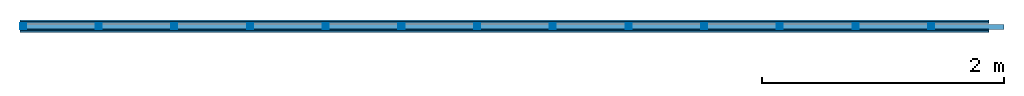
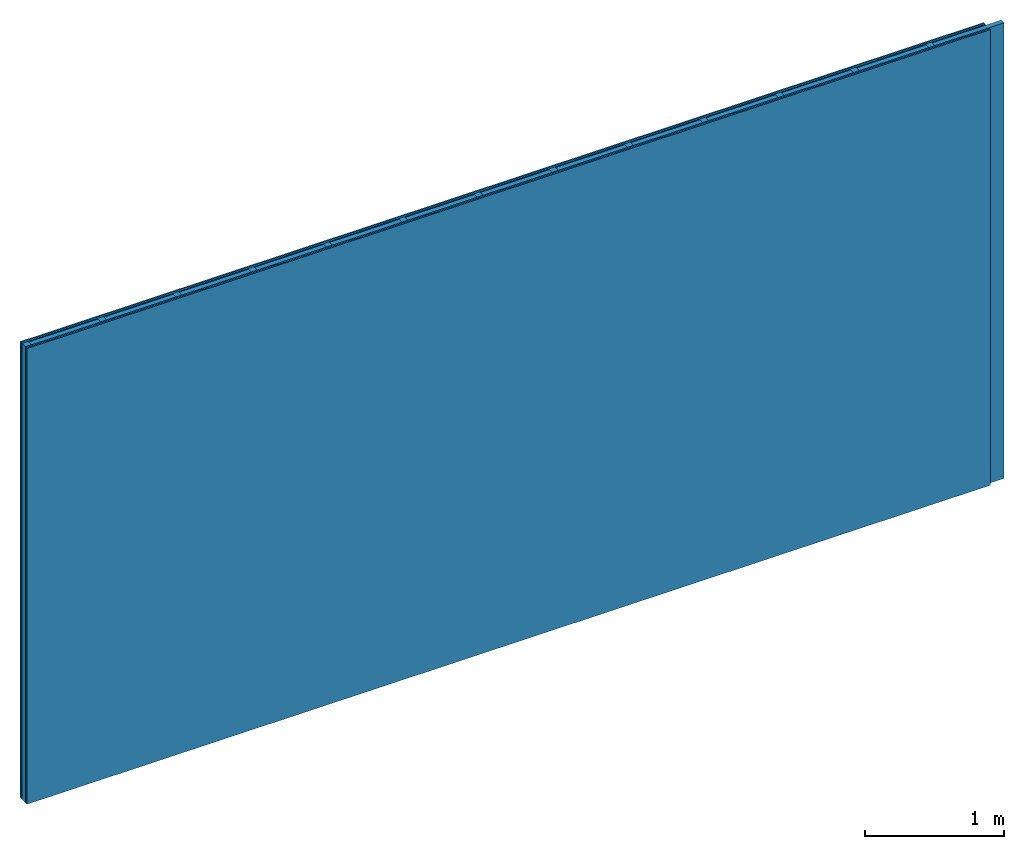
# One storey: 4 plates, 2 members, 1 element without a shape of its own.
"""IFC4 building model written with IfcOpenShell, lengths in metres."""

from ifc_helpers import new_model, si_unit, derived_unit, direction, frame, frame_2d, origin, origin_with_axes, place, context, project, spatial, rectangle, extrude, material, layer, layer_set, type_object, element, aggregate, save


model = new_model("IFC4")

# Units and contexts
plan_context = context("Plan", 3, precision=1e-05, world=origin(), true_north=direction((0.0, 1.0)))
model_context = context("Model", 3, precision=1e-05, world=origin(), true_north=direction((0.0, 1.0)))
ifc_project = project(units=[si_unit("LENGTHUNIT", "METRE"), derived_unit("SOUNDPRESSUREUNIT", [(si_unit("PRESSUREUNIT", "PASCAL", prefix="MICRO"), 0)]), si_unit("ENERGYUNIT", "JOULE", prefix="MEGA"), si_unit("MASSUNIT", "GRAM", prefix="KILO"), derived_unit("THERMALTRANSMITTANCEUNIT", [(si_unit("POWERUNIT", "WATT"), 1), (si_unit("AREAUNIT", "SQUARE_METRE"), -1), (si_unit("THERMODYNAMICTEMPERATUREUNIT", "KELVIN"), -1)]), derived_unit("AREADENSITYUNIT", [(si_unit("MASSUNIT", "GRAM", prefix="KILO"), 1), (si_unit("AREAUNIT", "SQUARE_METRE"), -1)]), derived_unit("USERDEFINED", [(si_unit("ENERGYUNIT", "JOULE", prefix="MEGA"), 1), (si_unit("AREAUNIT", "SQUARE_METRE"), -1)])], contexts=[plan_context, model_context])

# Site, building, storey
site = spatial("IfcSite", under=ifc_project)
building_placement = place(None, origin())
building = spatial("IfcBuilding", under=site, at=building_placement)
storey_placement = place(building_placement, origin())
storey = spatial("IfcBuildingStorey", under=building, at=storey_placement)

# Wall, members, plates
ifc_material_1 = material(Name="joints", Category="04.017")
ifc_layer_1 = layer(ifc_material_1, 0.0, Name="Surface")
ifc_material_2 = material(Name="Plasterboard type A", Category="03.008")
ifc_layer_2 = layer(ifc_material_2, 0.0125, Name="2nd layer")
ifc_material_3 = material(Name="Phone PLUS TRI", Category="03.013")
ifc_layer_3 = layer(ifc_material_3, 0.015, Name="1st layer")
ifc_material_4 = material(Name="of the art")
ifc_layer_4 = layer(ifc_material_4, 0.0, Name="Bond")
ifc_layer_5 = layer(None, 0.05, Name="Support")
ifc_layer_6 = layer(ifc_material_4, 0.0, Name="Bond")
ifc_material_5 = material(Name="Phone TRI ST Star", Category="03.013")
ifc_layer_7 = layer(ifc_material_5, 0.0125, Name="1st layer")
ifc_layer_8 = layer(ifc_material_2, 0.0125, Name="2nd layer")
ifc_layer_9 = layer(ifc_material_1, 0.0, Name="Surface")
ifc_layer_set = layer_set([ifc_layer_1, ifc_layer_2, ifc_layer_3, ifc_layer_4, ifc_layer_5, ifc_layer_6, ifc_layer_7, ifc_layer_8, ifc_layer_9])
wall_type = type_object("IfcWallType", Name="C0461", PredefinedType="NOTDEFINED", material=ifc_layer_set)
wall_placement = place(None, frame((0.0, 0.0, 0.0), z_axis=(0.0, -1.0, 0.0), x_axis=(1.0, 0.0, 0.0)))
wall = element("IfcWall", 1, at=wall_placement, inside=storey, type_object=wall_type, material=ifc_layer_set, Name="Wall #1")
ifc_material_6 = material()
member_1_placement = place(wall_placement, origin())
member_1 = element("IfcMember", 2, at=member_1_placement, material=ifc_material_6, Name="Support", context=plan_context, shape_type="SweptSolid", body=[
    extrude(rectangle(XDim=0.05, YDim=0.05, at=frame_2d((0.025, 0.025), x_axis=(1.0, 0.0))), frame((0.0, 4.0, 0.0275), z_axis=(0.0, -1.0, 0.0), x_axis=(1.0, 0.0, 0.0)), (0.0, 0.0, 1.0), 4.0),
    extrude(rectangle(XDim=0.05, YDim=0.05, at=frame_2d((0.025, 0.025), x_axis=(1.0, 0.0))), frame((0.625, 4.0, 0.0275), z_axis=(0.0, -1.0, 0.0), x_axis=(1.0, 0.0, 0.0)), (0.0, 0.0, 1.0), 4.0),
    extrude(rectangle(XDim=0.05, YDim=0.05, at=frame_2d((0.025, 0.025), x_axis=(1.0, 0.0))), frame((1.25, 4.0, 0.0275), z_axis=(0.0, -1.0, 0.0), x_axis=(1.0, 0.0, 0.0)), (0.0, 0.0, 1.0), 4.0),
    extrude(rectangle(XDim=0.05, YDim=0.05, at=frame_2d((0.025, 0.025), x_axis=(1.0, 0.0))), frame((1.875, 4.0, 0.0275), z_axis=(0.0, -1.0, 0.0), x_axis=(1.0, 0.0, 0.0)), (0.0, 0.0, 1.0), 4.0),
    extrude(rectangle(XDim=0.05, YDim=0.05, at=frame_2d((0.025, 0.025), x_axis=(1.0, 0.0))), frame((2.5, 4.0, 0.0275), z_axis=(0.0, -1.0, 0.0), x_axis=(1.0, 0.0, 0.0)), (0.0, 0.0, 1.0), 4.0),
    extrude(rectangle(XDim=0.05, YDim=0.05, at=frame_2d((0.025, 0.025), x_axis=(1.0, 0.0))), frame((3.125, 4.0, 0.0275), z_axis=(0.0, -1.0, 0.0), x_axis=(1.0, 0.0, 0.0)), (0.0, 0.0, 1.0), 4.0),
    extrude(rectangle(XDim=0.05, YDim=0.05, at=frame_2d((0.025, 0.025), x_axis=(1.0, 0.0))), frame((3.75, 4.0, 0.0275), z_axis=(0.0, -1.0, 0.0), x_axis=(1.0, 0.0, 0.0)), (0.0, 0.0, 1.0), 4.0),
    extrude(rectangle(XDim=0.05, YDim=0.05, at=frame_2d((0.025, 0.025), x_axis=(1.0, 0.0))), frame((4.375, 4.0, 0.0275), z_axis=(0.0, -1.0, 0.0), x_axis=(1.0, 0.0, 0.0)), (0.0, 0.0, 1.0), 4.0),
    extrude(rectangle(XDim=0.05, YDim=0.05, at=frame_2d((0.025, 0.025), x_axis=(1.0, 0.0))), frame((5.0, 4.0, 0.0275), z_axis=(0.0, -1.0, 0.0), x_axis=(1.0, 0.0, 0.0)), (0.0, 0.0, 1.0), 4.0),
    extrude(rectangle(XDim=0.05, YDim=0.05, at=frame_2d((0.025, 0.025), x_axis=(1.0, 0.0))), frame((5.625, 4.0, 0.0275), z_axis=(0.0, -1.0, 0.0), x_axis=(1.0, 0.0, 0.0)), (0.0, 0.0, 1.0), 4.0),
    extrude(rectangle(XDim=0.05, YDim=0.05, at=frame_2d((0.025, 0.025), x_axis=(1.0, 0.0))), frame((6.25, 4.0, 0.0275), z_axis=(0.0, -1.0, 0.0), x_axis=(1.0, 0.0, 0.0)), (0.0, 0.0, 1.0), 4.0),
    extrude(rectangle(XDim=0.05, YDim=0.05, at=frame_2d((0.025, 0.025), x_axis=(1.0, 0.0))), frame((6.875, 4.0, 0.0275), z_axis=(0.0, -1.0, 0.0), x_axis=(1.0, 0.0, 0.0)), (0.0, 0.0, 1.0), 4.0),
    extrude(rectangle(XDim=0.05, YDim=0.05, at=frame_2d((0.025, 0.025), x_axis=(1.0, 0.0))), frame((7.5, 4.0, 0.0275), z_axis=(0.0, -1.0, 0.0), x_axis=(1.0, 0.0, 0.0)), (0.0, 0.0, 1.0), 4.0),
])
ifc_material_7 = material()
member_2_placement = place(wall_placement, origin())
member_2 = element("IfcMember", 3, at=member_2_placement, material=ifc_material_7, Name="Cavity", context=plan_context, shape_type="SweptSolid", body=[
    extrude(rectangle(XDim=0.575, YDim=0.04, at=frame_2d((0.2875, 0.02), x_axis=(1.0, 0.0))), frame((0.05, 4.0, 0.0375), z_axis=(0.0, -1.0, 0.0), x_axis=(1.0, 0.0, 0.0)), (0.0, 0.0, 1.0), 4.0),
    extrude(rectangle(XDim=0.575, YDim=0.04, at=frame_2d((0.2875, 0.02), x_axis=(1.0, 0.0))), frame((0.675, 4.0, 0.0375), z_axis=(0.0, -1.0, 0.0), x_axis=(1.0, 0.0, 0.0)), (0.0, 0.0, 1.0), 4.0),
    extrude(rectangle(XDim=0.575, YDim=0.04, at=frame_2d((0.2875, 0.02), x_axis=(1.0, 0.0))), frame((1.3, 4.0, 0.0375), z_axis=(0.0, -1.0, 0.0), x_axis=(1.0, 0.0, 0.0)), (0.0, 0.0, 1.0), 4.0),
    extrude(rectangle(XDim=0.575, YDim=0.04, at=frame_2d((0.2875, 0.02), x_axis=(1.0, 0.0))), frame((1.925, 4.0, 0.0375), z_axis=(0.0, -1.0, 0.0), x_axis=(1.0, 0.0, 0.0)), (0.0, 0.0, 1.0), 4.0),
    extrude(rectangle(XDim=0.575, YDim=0.04, at=frame_2d((0.2875, 0.02), x_axis=(1.0, 0.0))), frame((2.55, 4.0, 0.0375), z_axis=(0.0, -1.0, 0.0), x_axis=(1.0, 0.0, 0.0)), (0.0, 0.0, 1.0), 4.0),
    extrude(rectangle(XDim=0.575, YDim=0.04, at=frame_2d((0.2875, 0.02), x_axis=(1.0, 0.0))), frame((3.175, 4.0, 0.0375), z_axis=(0.0, -1.0, 0.0), x_axis=(1.0, 0.0, 0.0)), (0.0, 0.0, 1.0), 4.0),
    extrude(rectangle(XDim=0.575, YDim=0.04, at=frame_2d((0.2875, 0.02), x_axis=(1.0, 0.0))), frame((3.8, 4.0, 0.0375), z_axis=(0.0, -1.0, 0.0), x_axis=(1.0, 0.0, 0.0)), (0.0, 0.0, 1.0), 4.0),
    extrude(rectangle(XDim=0.575, YDim=0.04, at=frame_2d((0.2875, 0.02), x_axis=(1.0, 0.0))), frame((4.425, 4.0, 0.0375), z_axis=(0.0, -1.0, 0.0), x_axis=(1.0, 0.0, 0.0)), (0.0, 0.0, 1.0), 4.0),
    extrude(rectangle(XDim=0.575, YDim=0.04, at=frame_2d((0.2875, 0.02), x_axis=(1.0, 0.0))), frame((5.05, 4.0, 0.0375), z_axis=(0.0, -1.0, 0.0), x_axis=(1.0, 0.0, 0.0)), (0.0, 0.0, 1.0), 4.0),
    extrude(rectangle(XDim=0.575, YDim=0.04, at=frame_2d((0.2875, 0.02), x_axis=(1.0, 0.0))), frame((5.675, 4.0, 0.0375), z_axis=(0.0, -1.0, 0.0), x_axis=(1.0, 0.0, 0.0)), (0.0, 0.0, 1.0), 4.0),
    extrude(rectangle(XDim=0.575, YDim=0.04, at=frame_2d((0.2875, 0.02), x_axis=(1.0, 0.0))), frame((6.3, 4.0, 0.0375), z_axis=(0.0, -1.0, 0.0), x_axis=(1.0, 0.0, 0.0)), (0.0, 0.0, 1.0), 4.0),
    extrude(rectangle(XDim=0.575, YDim=0.04, at=frame_2d((0.2875, 0.02), x_axis=(1.0, 0.0))), frame((6.925, 4.0, 0.0375), z_axis=(0.0, -1.0, 0.0), x_axis=(1.0, 0.0, 0.0)), (0.0, 0.0, 1.0), 4.0),
    extrude(rectangle(XDim=0.575, YDim=0.04, at=frame_2d((0.2875, 0.02), x_axis=(1.0, 0.0))), frame((7.55, 4.0, 0.0375), z_axis=(0.0, -1.0, 0.0), x_axis=(1.0, 0.0, 0.0)), (0.0, 0.0, 1.0), 4.0),
])
plate_1_placement = place(wall_placement, origin())
plate_1 = element("IfcPlate", 4, at=plate_1_placement, material=ifc_material_2, Name="2nd layer", context=plan_context, shape_type="SweptSolid", body=[
    extrude(rectangle(XDim=8.0, YDim=4.0, at=frame_2d((4.0, 2.0), x_axis=(1.0, 0.0))), origin_with_axes(), (0.0, 0.0, 1.0), 0.0125),
])
plate_2_placement = place(wall_placement, origin())
plate_2 = element("IfcPlate", 5, at=plate_2_placement, material=ifc_material_3, Name="1st layer", context=plan_context, shape_type="SweptSolid", body=[
    extrude(rectangle(XDim=8.0, YDim=4.0, at=frame_2d((4.0, 2.0), x_axis=(1.0, 0.0))), frame((0.0, 0.0, 0.0125), z_axis=(0.0, 0.0, 1.0), x_axis=(1.0, 0.0, 0.0)), (0.0, 0.0, 1.0), 0.015),
])
plate_3_placement = place(wall_placement, origin())
plate_3 = element("IfcPlate", 6, at=plate_3_placement, material=ifc_material_5, Name="1st layer", context=plan_context, shape_type="SweptSolid", body=[
    extrude(rectangle(XDim=8.0, YDim=4.0, at=frame_2d((4.0, 2.0), x_axis=(1.0, 0.0))), frame((0.0, 0.0, 0.0775), z_axis=(0.0, 0.0, 1.0), x_axis=(1.0, 0.0, 0.0)), (0.0, 0.0, 1.0), 0.0125),
])
plate_4_placement = place(wall_placement, origin())
plate_4 = element("IfcPlate", 7, at=plate_4_placement, material=ifc_material_2, Name="2nd layer", context=plan_context, shape_type="SweptSolid", body=[
    extrude(rectangle(XDim=8.0, YDim=4.0, at=frame_2d((4.0, 2.0), x_axis=(1.0, 0.0))), frame((0.0, 0.0, 0.09), z_axis=(0.0, 0.0, 1.0), x_axis=(1.0, 0.0, 0.0)), (0.0, 0.0, 1.0), 0.0125),
])
aggregate(wall, [plate_1, plate_2, member_1, member_2, plate_3, plate_4])

save(model, "model.ifc")
